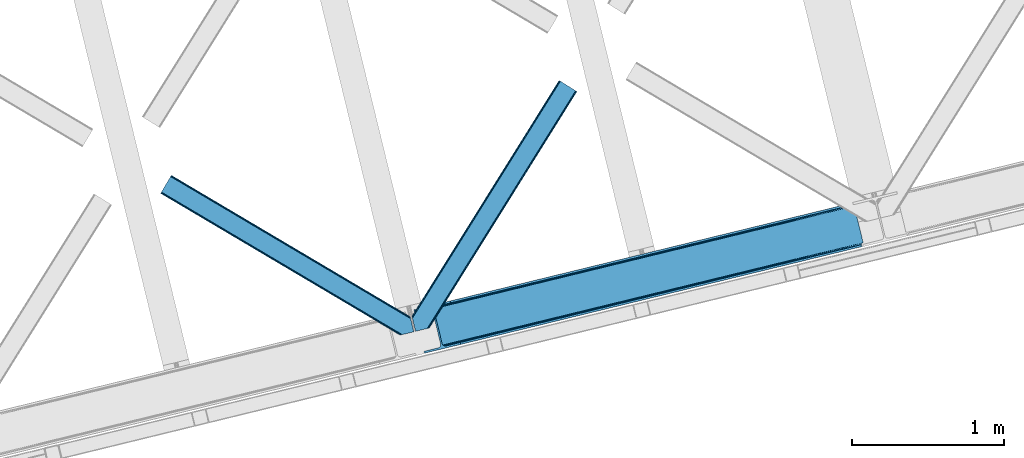
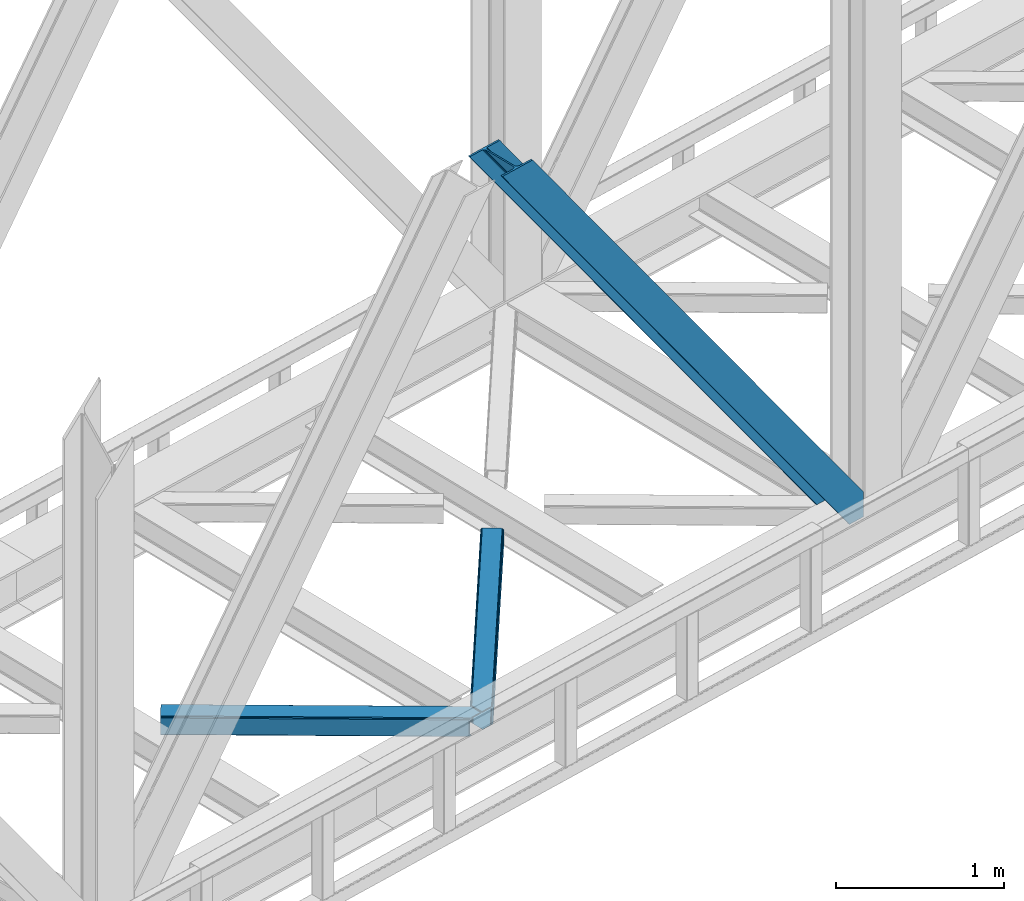
# One storey, part 64 of 93: 3 members.
"""IFC4 building model written with IfcOpenShell, lengths in millimetres."""

from ifc_helpers import new_model, entity, si_unit, converted_unit, derived_unit, direction, frame, origin, place, context, subcontext, project, spatial, triangles, type_object, element, save


model = new_model("IFC4")

# Units and contexts
model_context = context("Model", 3, precision=0.01, world=origin(), true_north=direction((6.12303176911189e-17, 1.0)))
plan_context = context("Plan", 3, precision=0.01, world=origin(), true_north=direction((6.12303176911189e-17, 1.0)))
body_context = subcontext(model_context, "Body", "Model", "MODEL_VIEW")
ifc_project = project(units=[si_unit("LENGTHUNIT", "METRE", prefix="MILLI"), si_unit("AREAUNIT", "SQUARE_METRE"), si_unit("VOLUMEUNIT", "CUBIC_METRE"), converted_unit("PLANEANGLEUNIT", "DEGREE", entity("IfcRatioMeasure", 0.0174532925199433), si_unit("PLANEANGLEUNIT", "RADIAN"), dimensions=[0, 0, 0, 0, 0, 0, 0]), si_unit("MASSUNIT", "GRAM", prefix="KILO"), derived_unit("MASSDENSITYUNIT", [(si_unit("MASSUNIT", "GRAM", prefix="KILO"), 1), (si_unit("LENGTHUNIT", "METRE"), -3)]), derived_unit("MOMENTOFINERTIAUNIT", [(si_unit("LENGTHUNIT", "METRE"), 4)]), si_unit("TIMEUNIT", "SECOND"), si_unit("FREQUENCYUNIT", "HERTZ"), si_unit("THERMODYNAMICTEMPERATUREUNIT", "DEGREE_CELSIUS"), derived_unit("THERMALTRANSMITTANCEUNIT", [(si_unit("MASSUNIT", "GRAM", prefix="KILO"), 1), (si_unit("THERMODYNAMICTEMPERATUREUNIT", "KELVIN"), -1), (si_unit("TIMEUNIT", "SECOND"), -3)]), derived_unit("VOLUMETRICFLOWRATEUNIT", [(si_unit("LENGTHUNIT", "METRE"), 3), (si_unit("TIMEUNIT", "SECOND"), -1)]), derived_unit("MASSFLOWRATEUNIT", [(si_unit("MASSUNIT", "GRAM", prefix="KILO"), 1), (si_unit("TIMEUNIT", "SECOND"), -1)]), derived_unit("ROTATIONALFREQUENCYUNIT", [(si_unit("TIMEUNIT", "SECOND"), -1)]), si_unit("ELECTRICCURRENTUNIT", "AMPERE"), si_unit("ELECTRICVOLTAGEUNIT", "VOLT"), si_unit("POWERUNIT", "WATT"), si_unit("FORCEUNIT", "NEWTON", prefix="KILO"), si_unit("ILLUMINANCEUNIT", "LUX"), si_unit("LUMINOUSFLUXUNIT", "LUMEN"), si_unit("LUMINOUSINTENSITYUNIT", "CANDELA"), derived_unit("USERDEFINED", [(si_unit("MASSUNIT", "GRAM", prefix="KILO"), -1), (si_unit("LENGTHUNIT", "METRE"), -2), (si_unit("TIMEUNIT", "SECOND"), 3), (si_unit("LUMINOUSFLUXUNIT", "LUMEN"), 1)]), derived_unit("LINEARVELOCITYUNIT", [(si_unit("LENGTHUNIT", "METRE"), 1), (si_unit("TIMEUNIT", "SECOND"), -1)]), si_unit("PRESSUREUNIT", "PASCAL"), derived_unit("USERDEFINED", [(si_unit("LENGTHUNIT", "METRE"), -2), (si_unit("MASSUNIT", "GRAM", prefix="KILO"), 1), (si_unit("TIMEUNIT", "SECOND"), -2)]), derived_unit("LINEARFORCEUNIT", [(si_unit("MASSUNIT", "GRAM", prefix="KILO"), 1), (si_unit("LENGTHUNIT", "METRE"), 1), (si_unit("TIMEUNIT", "SECOND"), -2), (si_unit("LENGTHUNIT", "METRE"), -1)]), derived_unit("PLANARFORCEUNIT", [(si_unit("MASSUNIT", "GRAM", prefix="KILO"), 1), (si_unit("LENGTHUNIT", "METRE"), 1), (si_unit("TIMEUNIT", "SECOND"), -2), (si_unit("LENGTHUNIT", "METRE"), -2)])], contexts=[model_context, plan_context])

# Site, building, storey
site_placement = place(None, origin())
site = spatial("IfcSite", under=ifc_project, at=site_placement, CompositionType="ELEMENT")
building_placement = place(site_placement, origin())
building = spatial("IfcBuilding", under=site, at=building_placement, CompositionType="ELEMENT")
storey_placement = place(building_placement, frame((0.0, 0.0, 15900.0)))
storey = spatial("IfcBuildingStorey", under=building, at=storey_placement, CompositionType="ELEMENT", Elevation=15900.0)

# Members
member_type_1 = type_object("IfcMemberType", PredefinedType="BRACE")
member_1_placement = place(storey_placement, frame((-20226.1607666016, 12536.4475799561, 3694.99929199219)))
element("IfcMember", 1, at=member_1_placement, inside=storey, type_object=member_type_1, ObjectType="Steel Vertical Brace", PredefinedType="BRACE", context=body_context, shape_type="Tessellation", body=[
    triangles([(2966.89216003418, 730.998403930664, 0.80925292968459), (2967.55374755859, 730.015905761718, 1.10690917968532), (2966.08058166504, 729.656625366211, 0.0), (2964.18534851074, 737.429406738282, 0.0), (2962.43778076172, 728.769470214844, 8.31577148437282), (2962.43778076172, 728.769470214844, 0.0), (2505.8586730957, 612.60679321289, 658.855133056641), (2511.36415100098, 609.932537841796, 662.301434326171), (2954.04410705566, 717.839904785156, 38.6743835449197), (2954.16851806641, 719.764205932617, 32.1678039550752), (2501.4112701416, 617.533236694337, 656.552947998047), (2958.54266967773, 726.957952880859, 14.8293273925774), (2955.07776489258, 722.243124389648, 26.1867736816384), (2955.64168395996, 723.796517944336, 22.4381652832017), (655.166986083983, 156.054428100586, 3289.34108276367), (649.44175415039, 156.069543457032, 3285.27854003906), (213.882293701172, 48.4865753173835, 3911.00081176758), (205.271191406249, 47.7982452392571, 3911.00081176758), (643.935113525389, 158.742636108398, 3281.83223876953), (197.320513916016, 49.8760253906257, 3911.00081176758), (639.488873291015, 163.67024230957, 3279.53005371094), (191.241815185545, 54.4048187255867, 3911.00081176758), (636.782061767579, 170.100082397461, 3278.7231262207), (187.962945556639, 60.6951324462898, 3911.00081176758), (2954.16037902832, 716.45859375, 50.6410949707024), (2517.08822021484, 609.917422485352, 666.36397705078), (2051.60733032227, 496.451092529296, 1322.10767211914), (2045.8832611084, 496.466207885742, 1318.04512939453), (1580.40353393555, 383.001040649415, 1973.78882446289), (1586.12760314941, 382.985925292969, 1977.85369262695), (1114.92264404297, 269.534710693359, 2629.53251953125), (1120.64671325684, 269.519595336915, 2633.59738769531), (2040.37778320312, 499.140463256836, 1314.598828125), (1574.89689331055, 385.675296020509, 1970.34484863281), (1109.41600341797, 272.208966064452, 2626.08854370117), (2035.93154296875, 504.066906738281, 1312.29896850586), (1570.45065307617, 390.601739501953, 1968.04266357422), (1104.96976318359, 277.135409545899, 2623.78635864258), (2498.70445861816, 623.963076782227, 655.74602050781), (2033.22473144531, 510.497909545898, 1311.48971557617), (1567.74384155273, 397.031579589844, 1967.23341064453), (1102.26295166016, 283.566412353515, 2622.97710571289), (2909.00499572754, 963.80047302246, 0.0), (2443.52410583496, 850.335305786133, 655.74602050781), (1978.04437866211, 736.868975830079, 1311.48971557617), (1512.56348876953, 623.40380859375, 1967.23341064453), (1047.08259887695, 509.937478637696, 2622.97710571289), (581.601708984374, 396.471148681641, 3278.7231262207), (132.782592773438, 287.067361450196, 3911.00081176758), (307.434722900391, 71.2909973144524, 3911.00081176758), (2954.16037902832, 716.45859375, 182.433050537107), (2954.3522277832, 715.476095581054, 0.0), (2954.16851806641, 719.764205932617, 0.0), (2954.3522277832, 715.476095581054, 182.495837402341), (2955.64168395996, 723.796517944336, 0.0), (2958.54266967773, 726.957952880859, 0.0), (2957.19391479492, 703.817504882813, 182.495837402341), (310.513604736327, 58.6603729248054, 3911.00081176758), (2957.19391479492, 703.817504882813, 0.0), (2846.09139404297, 676.734274291992, 0.0), (69.8631774902351, 0.0, 3911.00081176758), (2843.01251220703, 689.364898681641, 0.0), (66.7842956542954, 12.6294616699215, 3911.00081176758), (160.336724853514, 35.4338836669922, 3911.00081176758), (2936.56494140625, 712.169320678711, 0.0), (2953.96039123535, 734.936535644531, 0.0), (2953.94178771973, 727.841619873047, 0.0), (177.731011962889, 58.2010986328132, 3911.00081176758), (177.719384765624, 51.108508300782, 3911.00081176758), (2950.63036193847, 721.02459411621, 0.0), (174.403308105469, 44.2891571044929, 3911.00081176758), (2944.52840881348, 715.520278930664, 0.0), (168.299029541016, 38.7860046386722, 3911.00081176758), (2898.78003845215, 961.308764648438, 0.0), (122.550659179688, 284.573327636719, 3911.00081176758), (2872.85952758789, 973.517321777344, 0.0), (2881.47062988281, 974.205651855469, 0.0), (105.242413330077, 297.47021484375, 3911.00081176758), (96.6313110351548, 296.781884765625, 3911.00081176758), (2889.42130737305, 972.127871704102, 0.0), (113.19309082031, 295.392434692383, 3911.00081176758), (2895.49884338379, 967.599078369141, 0.0), (119.276440429687, 290.864804077148, 3911.00081176758), (3.07888183593604, 273.977462768555, 3911.00081176758), (2779.30709838867, 950.712899780274, 0.0), (2776.22821655273, 963.342361450195, 0.0), (0.0, 286.608087158203, 3911.00081176758), (142.21457519531, 306.482455444337, 3911.00081176758), (150.176879882813, 309.834576416015, 3911.00081176758), (136.110296630857, 300.979302978516, 3911.00081176758), (132.798870849609, 294.161114501952, 3911.00081176758), (240.650427246092, 345.268460083007, 3911.00081176758), (243.729309082031, 332.638998413086, 3911.00081176758), (2887.33073730469, 990.425592041016, 182.495837402341), (2887.33073730469, 990.425592041016, 0.0), (2890.45496520996, 977.805432128906, 182.433050537107), (2890.17242431641, 978.767001342774, 182.495837402341), (1522.42102661133, 644.332763671875, 1977.85369262695), (591.459246826173, 417.401266479492, 3289.34108276367), (1056.94013671875, 530.867596435546, 2633.59738769531), (1987.90191650391, 757.799093627929, 1322.10767211914), (2453.38164367676, 871.265423583984, 666.36397705078), (2890.45496520996, 977.805432128906, 50.6410949707024), (2890.17242431641, 978.767001342774, 0.0), (2890.986328125, 976.525277709961, 38.6743835449197), (2892.14904785156, 974.998626708984, 33.1630920410134), (2891.98277893066, 974.875378417968, 0.0), (2893.5687286377, 973.138275146484, 26.4425720214822), (2895.14653930664, 971.973229980469, 22.4381652832017), (2903.46812438965, 970.684936523438, 8.31577148437282), (2903.46812438965, 970.684936523438, 0.0), (2899.17652587891, 970.50122680664, 0.0), (2899.17652587891, 970.50122680664, 14.8293273925774), (2895.14653930664, 971.973229980469, 0.0), (2907.11092529297, 971.573254394531, 0.0), (2444.64961853027, 863.710070800782, 658.855133056641), (2442.96832580566, 857.289532470702, 656.552947998047), (2908.44921569824, 970.755862426759, 0.80925292968459), (2908.58409118652, 971.932534790039, 1.10690917968532), (581.045928955078, 403.426538085938, 3279.53005371094), (582.727221679688, 409.845913696288, 3281.83223876953), (586.385137939451, 414.753753662109, 3285.27854003906), (2448.30753479004, 868.617910766601, 662.301434326171), (1977.48859863281, 743.823202514648, 1312.29896850586), (1512.00770874024, 630.358035278321, 1968.04266357422), (1046.52681884765, 516.891705322265, 2623.78635864258), (1979.16872863769, 750.243740844726, 1314.598828125), (1513.68783874512, 636.778573608399, 1970.34484863281), (1048.20694885254, 523.312243652344, 2626.08854370117), (1982.82664489746, 755.151580810547, 1318.04512939453), (1517.34575500488, 641.686413574218, 1973.78882446289), (1051.8648651123, 528.220083618164, 2629.53251953125)], [[1, 2, 3], [3, 4, 1], [2, 5, 6], [6, 3, 2], [7, 8, 9], [9, 10, 7], [11, 12, 5], [5, 1, 11], [11, 7, 13], [13, 14, 11], [14, 12, 11], [15, 16, 17], [18, 17, 16], [16, 19, 18], [20, 18, 19], [19, 21, 20], [22, 20, 21], [21, 23, 22], [24, 22, 23], [5, 2, 1], [10, 13, 7], [25, 9, 8], [8, 26, 25], [26, 8, 27], [28, 27, 8], [27, 28, 29], [29, 30, 27], [30, 29, 31], [31, 32, 30], [32, 31, 16], [16, 15, 32], [8, 7, 33], [33, 28, 8], [28, 33, 29], [34, 29, 33], [29, 34, 31], [35, 31, 34], [31, 35, 16], [19, 16, 35], [7, 11, 33], [36, 33, 11], [33, 36, 34], [37, 34, 36], [34, 37, 35], [38, 35, 37], [35, 38, 21], [21, 19, 35], [1, 4, 39], [39, 11, 1], [11, 39, 40], [40, 36, 11], [36, 40, 41], [41, 37, 36], [37, 41, 42], [42, 38, 37], [38, 42, 23], [23, 21, 38], [4, 43, 44], [45, 39, 44], [41, 40, 45], [41, 45, 46], [44, 39, 4], [45, 40, 39], [42, 41, 46], [46, 47, 42], [47, 48, 23], [49, 24, 48], [47, 23, 42], [48, 24, 23], [50, 51, 30], [30, 32, 50], [32, 15, 50], [17, 50, 15], [27, 30, 51], [51, 25, 26], [26, 27, 51], [52, 9, 25], [52, 53, 10], [10, 9, 52], [25, 51, 54], [54, 52, 25], [14, 53, 55], [53, 14, 13], [10, 53, 13], [56, 12, 55], [14, 55, 12], [6, 5, 56], [12, 56, 5], [57, 54, 58], [54, 51, 50], [50, 58, 54], [57, 59, 52], [52, 54, 57], [58, 60, 57], [58, 61, 60], [60, 59, 57], [62, 60, 61], [61, 63, 62], [63, 64, 62], [65, 62, 64], [66, 67, 68], [69, 68, 67], [67, 70, 69], [71, 69, 70], [70, 72, 71], [73, 71, 72], [72, 65, 73], [64, 73, 65], [74, 66, 68], [68, 75, 74], [76, 77, 78], [78, 79, 76], [77, 80, 81], [81, 78, 77], [80, 82, 83], [83, 81, 80], [82, 74, 75], [75, 83, 82], [79, 84, 85], [85, 76, 79], [86, 85, 87], [84, 87, 85], [75, 68, 49], [71, 73, 18], [64, 61, 17], [63, 61, 64], [73, 64, 17], [68, 69, 22], [69, 71, 20], [81, 88, 78], [87, 79, 89], [79, 78, 89], [87, 84, 79], [81, 83, 90], [83, 75, 91], [49, 68, 24], [17, 18, 73], [22, 69, 20], [18, 20, 71], [22, 24, 68], [58, 17, 61], [58, 50, 17], [89, 78, 88], [90, 83, 91], [49, 91, 75], [90, 88, 81], [89, 92, 87], [92, 89, 93], [92, 86, 87], [86, 92, 94], [95, 86, 94], [96, 97, 93], [97, 94, 92], [92, 93, 97], [98, 96, 93], [93, 99, 100], [99, 93, 89], [100, 98, 93], [96, 98, 101], [101, 102, 96], [103, 96, 102], [97, 104, 94], [95, 94, 104], [104, 105, 106], [96, 103, 97], [104, 97, 103], [103, 105, 104], [107, 108, 109], [107, 106, 108], [110, 111, 112], [112, 113, 110], [113, 112, 114], [114, 109, 113], [109, 114, 107], [106, 107, 104], [53, 70, 55], [76, 86, 95], [85, 86, 76], [77, 76, 95], [104, 80, 77], [77, 95, 104], [104, 107, 80], [60, 65, 59], [52, 72, 70], [65, 72, 59], [60, 62, 65], [70, 53, 52], [52, 59, 72], [43, 66, 74], [82, 112, 74], [80, 114, 82], [80, 107, 114], [82, 114, 112], [111, 43, 74], [112, 111, 74], [43, 111, 115], [4, 66, 43], [56, 66, 6], [55, 70, 67], [67, 66, 56], [56, 55, 67], [4, 6, 66], [3, 6, 4], [116, 113, 109], [117, 118, 113], [113, 116, 117], [109, 108, 116], [118, 119, 110], [110, 113, 118], [48, 120, 91], [91, 49, 48], [120, 121, 90], [90, 91, 120], [121, 122, 88], [88, 90, 121], [122, 99, 89], [89, 88, 122], [105, 103, 123], [102, 123, 103], [106, 116, 108], [116, 106, 105], [123, 116, 105], [43, 118, 44], [117, 44, 118], [44, 117, 45], [124, 45, 117], [45, 124, 46], [125, 46, 124], [46, 125, 47], [126, 47, 125], [47, 126, 48], [120, 48, 126], [117, 116, 127], [127, 124, 117], [124, 127, 128], [128, 125, 124], [125, 128, 129], [129, 126, 125], [126, 129, 121], [121, 120, 126], [116, 123, 127], [130, 127, 123], [127, 130, 131], [131, 128, 127], [128, 131, 132], [132, 129, 128], [129, 132, 122], [122, 121, 129], [123, 102, 101], [101, 130, 123], [130, 101, 131], [98, 131, 101], [131, 98, 132], [100, 132, 98], [132, 100, 122], [99, 122, 100], [110, 119, 111], [115, 111, 119], [119, 118, 115], [43, 115, 118]]),
])
member_type_2 = type_object("IfcMemberType", PredefinedType="BRACE")
member_2_placement = place(storey_placement, frame((-20238.8832458496, 12681.0701477051, 3510.00011901855)))
element("IfcMember", 2, at=member_2_placement, inside=storey, type_object=member_type_2, ObjectType="Steel Horizontal Brace", PredefinedType="BRACE", context=body_context, shape_type="Tessellation", body=[
    triangles([(986.150271606446, 1647.42851257324, 0.0), (1075.22041625977, 1591.8260925293, 0.0), (119.788037109374, 259.603921508789, 0.0), (154.548706054688, 117.003323364257, 0.0), (115.902227783205, 275.544808959961, 4.52065429687718), (117.571893310549, 268.698715209961, 1.33247680664135), (158.434515380861, 101.062435913085, 4.52065429687718), (156.767175292971, 107.908529663086, 1.33247680664135), (114.825549316407, 275.742471313477, 5.52059326172093), (115.130181884768, 275.922692871094, 5.35316162109666), (158.132208251955, 99.1218566894531, 5.27525939941552), (115.439465332031, 276.107565307617, 5.18107910156323), (158.236853027345, 99.7776306152336, 5.02062377929906), (158.188018798828, 99.4811370849602, 5.13573303222802), (115.54178466797, 276.166864013672, 5.12526855468968), (115.685961914063, 275.921530151367, 4.88574829101708), (158.339172363281, 100.434567260741, 4.76482543945531), (158.032214355469, 98.4928253173821, 5.52059326172093), (1085.71628723145, 1585.27300415039, 5.12526855468968), (1080.90495300293, 1588.28096008301, 1.33247680664135), (1088.93469543457, 1583.26498718262, 10.8028289794929), (114.209307861329, 21.8521545410149, 10.8028289794929), (109.470062255859, 20.6964111328125, 5.52059326172093), (1090.0695098877, 1582.56037902832, 17.5000946044929), (116.062683105469, 22.3044525146488, 17.5000946044929), (6.7507507324226, 102.618154907226, 5.52059326172093), (31.3608764648452, 1.65687561035156, 5.52059326172093), (1090.0695098877, 1582.56037902832, 122.500662231447), (116.062683105469, 22.3044525146488, 122.500662231447), (1088.93469543457, 1583.26498718262, 129.197927856447), (114.209307861329, 21.8521545410149, 129.197927856447), (1085.71628723145, 1585.27300415039, 134.874325561526), (108.935211181641, 20.5673492431633, 134.874325561526), (1080.90495300293, 1588.28096008301, 138.667117309571), (101.042669677736, 18.6430480957024, 138.667117309571), (1075.22041625977, 1591.8260925293, 139.999594116212), (91.7292846679702, 16.3722564697255, 139.999594116212), (980.470385742188, 1650.97480773926, 1.33247680664135), (975.654400634765, 1653.98160095215, 5.12526855468968), (1.68826904297021, 100.410150146485, 10.9621215820334), (972.435992431641, 1655.99078063965, 10.8028289794929), (971.306991577148, 1656.69655151367, 17.5000946044929), (0.239520263672603, 99.7776306152336, 12.5201660156272), (0.0, 100.760128784179, 17.5000946044929), (5.79266967773583, 76.992974853516, 139.999594116212), (986.150271606446, 1647.42851257324, 139.999594116212), (24.5612915039055, 0.0, 139.999594116212), (971.306991577148, 1656.69655151367, 122.500662231447), (0.0, 100.760128784179, 122.500662231447), (980.470385742188, 1650.97480773926, 138.667117309571), (3.57652587890698, 86.088931274413, 138.667117309571), (975.654400634765, 1653.98160095215, 134.874325561526), (1.69524536133031, 93.7989257812496, 134.874325561526), (972.435992431641, 1655.99078063965, 129.197927856447), (0.439508056642808, 98.9509368896488, 129.197927856447), (29.9237548828132, 1.30689697265552, 6.99957275390625), (12.1969299316406, 74.0326904296871, 6.99957275390625), (8.99479980468823, 81.5485107421864, 8.3320495605476), (3.88813476562427, 84.8111022949215, 12.5201660156272), (1069.28589477539, 1595.53400573731, 6.99957275390625), (81.9973205566421, 14.000308227538, 6.99957275390625), (992.090606689453, 1643.72176208496, 6.99957275390625), (981.593572998048, 1650.27485046387, 12.1260040283232), (978.375164794921, 1652.28403015137, 17.8035644531265), (2.75797119140771, 89.4445404052731, 17.8035644531265), (986.409558105468, 1647.2692199707, 8.3320495605476), (977.246163940432, 1652.98980102539, 24.4996673583992), (2.31613769531396, 91.2537322998051, 24.4996673583992), (977.246163940432, 1652.98980102539, 115.501089477541), (2.31613769531396, 91.2537322998051, 115.501089477541), (4.01370849609521, 84.2925292968739, 127.87475280762), (2.75797119140771, 89.4445404052731, 122.196029663086), (5.89266357422093, 76.5813720703118, 131.667544555665), (8.11113281250073, 67.4865783691403, 133.000021362306), (24.5612915039055, 0.0, 133.000021362306), (978.375164794921, 1652.28403015137, 122.196029663086), (981.593572998048, 1650.27485046387, 127.87475280762), (986.409558105468, 1647.2692199707, 131.667544555665), (992.090606689453, 1643.72176208496, 133.000021362306), (1069.28589477539, 1595.53400573731, 133.000021362306), (81.9973205566421, 14.000308227538, 133.000021362306), (1079.78176574707, 1588.9809173584, 12.1260040283232), (1083.0001739502, 1586.9717376709, 17.8035644531265), (1084.12917480469, 1586.2671295166, 24.4996673583992), (1074.96578063965, 1591.98771057129, 8.3320495605476), (1079.78176574707, 1588.9809173584, 127.87475280762), (1084.12917480469, 1586.2671295166, 115.501089477541), (1083.0001739502, 1586.9717376709, 122.196029663086), (1074.96578063965, 1591.98771057129, 131.667544555665), (91.3083801269531, 16.2699371337894, 131.667544555665), (99.2032470703125, 18.1942382812504, 127.87475280762), (104.477343750001, 19.4802062988274, 122.196029663086), (106.32839355469, 19.931341552734, 115.501089477541), (91.3083801269531, 16.2699371337894, 8.3320495605476), (104.477343750001, 19.4802062988274, 17.8035644531265), (99.2032470703125, 18.1942382812504, 12.1260040283232), (106.32839355469, 19.931341552734, 24.4996673583992)], [[1, 2, 3], [4, 3, 2], [5, 3, 4], [3, 5, 6], [4, 7, 5], [7, 4, 8], [9, 10, 11], [10, 12, 13], [13, 14, 10], [12, 15, 16], [16, 17, 12], [16, 5, 7], [7, 17, 16], [17, 13, 12], [14, 11, 10], [11, 18, 9], [19, 14, 13], [13, 20, 19], [13, 17, 20], [17, 7, 20], [7, 8, 20], [21, 22, 18], [18, 19, 21], [14, 19, 11], [18, 11, 19], [22, 23, 18], [21, 24, 25], [25, 22, 21], [2, 20, 4], [8, 4, 20], [23, 26, 18], [23, 27, 26], [9, 18, 26], [24, 28, 29], [29, 25, 24], [28, 30, 29], [31, 29, 30], [30, 32, 31], [33, 31, 32], [32, 34, 33], [35, 33, 34], [34, 36, 35], [37, 35, 36], [38, 6, 5], [5, 39, 38], [5, 15, 39], [40, 41, 9], [41, 39, 15], [42, 41, 40], [40, 43, 42], [43, 44, 42], [9, 26, 40], [38, 1, 6], [3, 6, 1], [36, 45, 37], [36, 46, 45], [45, 47, 37], [48, 42, 44], [44, 49, 48], [46, 50, 51], [51, 45, 46], [50, 52, 53], [53, 51, 50], [52, 54, 55], [55, 53, 52], [54, 48, 49], [49, 55, 54], [27, 56, 57], [26, 57, 58], [57, 26, 27], [59, 40, 26], [26, 58, 59], [43, 40, 59], [60, 57, 61], [60, 62, 57], [57, 56, 61], [63, 64, 65], [65, 59, 63], [66, 63, 59], [62, 66, 58], [58, 57, 62], [59, 58, 66], [64, 67, 68], [68, 65, 64], [67, 69, 68], [70, 68, 69], [71, 53, 72], [73, 74, 45], [74, 47, 45], [74, 75, 47], [51, 73, 45], [71, 51, 53], [71, 73, 51], [49, 68, 70], [55, 72, 53], [70, 72, 49], [72, 55, 49], [44, 68, 49], [43, 59, 65], [65, 68, 44], [44, 43, 65], [69, 76, 70], [72, 70, 76], [76, 77, 72], [71, 72, 77], [77, 78, 71], [73, 71, 78], [78, 79, 73], [74, 73, 79], [80, 74, 79], [74, 80, 81], [75, 74, 81], [21, 82, 83], [84, 28, 24], [21, 83, 24], [21, 19, 82], [83, 84, 24], [82, 19, 20], [60, 2, 1], [2, 85, 20], [85, 2, 60], [85, 82, 20], [30, 86, 32], [87, 28, 84], [28, 88, 30], [88, 28, 87], [30, 88, 86], [36, 80, 46], [34, 32, 86], [86, 89, 34], [89, 80, 36], [36, 34, 89], [63, 38, 39], [1, 62, 60], [1, 66, 62], [66, 1, 38], [63, 66, 38], [67, 42, 48], [41, 64, 63], [39, 41, 63], [64, 41, 42], [67, 64, 42], [50, 77, 52], [46, 80, 79], [79, 78, 46], [78, 77, 50], [50, 46, 78], [54, 52, 77], [48, 69, 67], [76, 48, 54], [48, 76, 69], [76, 54, 77], [35, 37, 90], [47, 81, 37], [81, 47, 75], [81, 90, 37], [91, 35, 90], [91, 33, 35], [33, 92, 31], [92, 33, 91], [29, 92, 93], [92, 29, 31], [61, 23, 94], [95, 96, 23], [96, 94, 23], [61, 27, 23], [27, 61, 56], [97, 95, 25], [22, 25, 95], [29, 97, 25], [97, 29, 93], [95, 23, 22], [80, 89, 90], [90, 81, 80], [89, 86, 91], [91, 90, 89], [86, 88, 92], [92, 91, 86], [88, 87, 93], [93, 92, 88], [87, 84, 97], [97, 93, 87], [84, 83, 97], [95, 97, 83], [83, 82, 95], [96, 95, 82], [82, 85, 96], [94, 96, 85], [85, 60, 94], [61, 94, 60]]),
])
member_type_3 = type_object("IfcMemberType", PredefinedType="BRACE")
member_3_placement = place(storey_placement, frame((-21897.5192138672, 12655.9240081787, 3510.00011901855)))
element("IfcMember", 3, at=member_3_placement, inside=storey, type_object=member_type_3, ObjectType="Steel Horizontal Brace", PredefinedType="BRACE", context=body_context, shape_type="Tessellation", body=[
    triangles([(1467.52902832031, 208.965151977538, 0.0), (1502.28969726562, 66.3657165527329, 0.0), (8.91573486327979, 950.478030395507, 0.0), (62.405493164064, 1040.83065490723, 0.0), (0.679028320311772, 936.564926147461, 10.8028289794929), (1582.26156005859, 0.541827392577034, 10.8679412841811), (1580.03843994141, 0.0, 17.5000946044929), (1508.64744873047, 44.5007720947251, 9.52034912109593), (2.6114685058601, 939.829843139647, 5.12526855468968), (1506.38479614258, 49.5597656249993, 5.12526855468968), (1507.26148681641, 45.9657989501939, 8.52041015625218), (1508.31258544922, 44.8554016113267, 9.27850341796875), (1507.95214233398, 45.2332855224595, 9.02037963867406), (1507.59635009766, 45.6123321533196, 8.76225585937573), (1582.7126953125, 0.651123046875, 9.52034912109593), (1504.50584106445, 57.2697601318359, 1.33247680664135), (5.50431518554615, 944.715591430664, 1.33247680664135), (0.0, 935.41848449707, 17.5000946044929), (1580.03843994141, 0.0, 122.500662231447), (0.0, 935.41848449707, 122.500662231447), (1595.05845336914, 3.66024169921729, 138.667117309571), (1604.36951293945, 5.93103332519422, 139.999594116212), (8.91573486327979, 950.478030395507, 139.999594116212), (5.50431518554615, 944.715591430664, 138.667117309571), (1587.16358642578, 1.73710327148365, 134.874325561526), (2.6114685058601, 939.829843139647, 134.874325561526), (1581.88948974609, 0.451135253904795, 129.197927856447), (0.679028320311772, 936.564926147461, 129.197927856447), (1502.33388061524, 66.183169555663, 8.52041015625218), (1502.68967285156, 65.0390533447262, 8.90294494629052), (1503.18034057617, 64.3204925537102, 9.10758361816625), (1503.67798461914, 63.5914672851559, 9.31571044922021), (1504.1709777832, 62.8729064941399, 9.52034912109593), (1601.52317504883, 5.23688964843677, 9.52034912109593), (9.07153930664208, 950.739642333983, 8.3320495605476), (1502.18272705078, 66.8063873291012, 8.42274169922166), (6.1786926269524, 945.853894042968, 12.1260040283232), (1596.89555053711, 4.10905151367115, 12.1260040283232), (1499.97123413086, 75.8721130371086, 6.99957275390625), (12.4829589843757, 956.502081298828, 6.99957275390625), (1591.62377929688, 2.82424621581958, 17.8035644531265), (4.24625244140771, 942.58897705078, 17.8035644531265), (1589.77040405274, 2.3719482421875, 24.4996673583992), (3.56722412109229, 941.442535400391, 24.4996673583992), (1469.84749145508, 199.458755493164, 6.99957275390625), (58.8429199218735, 1034.80776672363, 6.99957275390625), (1462.55723876953, 229.365069580077, 8.52041015625218), (1467.4848449707, 209.147698974608, 8.52041015625218), (1463.4316040039, 225.771102905273, 5.12526855468968), (1467.63599853516, 208.524481201172, 8.42274169922166), (1465.31288452149, 218.061108398437, 1.33247680664135), (1589.77040405274, 2.3719482421875, 115.501089477541), (3.56722412109229, 941.442535400391, 115.501089477541), (1591.62377929688, 2.82424621581958, 122.196029663086), (4.24625244140771, 942.58897705078, 122.196029663086), (1596.89555053711, 4.10905151367115, 127.87475280762), (6.1786926269524, 945.853894042968, 127.87475280762), (1604.79041748047, 6.03335266113208, 131.667544555665), (9.07153930664208, 950.739642333983, 131.667544555665), (1614.10380249023, 8.30298156738172, 133.000021362306), (12.4829589843757, 956.502081298828, 133.000021362306), (1671.53983154297, 22.304452514647, 139.999594116212), (1671.53983154297, 22.304452514647, 133.000021362306), (1652.7712097168, 99.297427368163, 139.999594116212), (62.405493164064, 1040.83065490723, 139.999594116212), (1655.08734741211, 89.7910308837891, 133.000021362306), (58.8429199218735, 1034.80776672363, 133.000021362306), (1647.4180480957, 121.255389404296, 129.197927856447), (1646.97854003906, 123.064581298828, 122.500662231447), (70.642199707032, 1054.74375915527, 129.197927856447), (71.3258789062493, 1055.89020080566, 122.500662231447), (1648.67378540039, 116.103378295898, 134.874325561526), (68.7144104003892, 1051.48000488281, 134.874325561526), (1650.55274047852, 108.393383789062, 138.667117309571), (65.8215637207031, 1046.5942565918, 138.667117309571), (1646.97854003906, 123.064581298828, 17.5000946044929), (71.3258789062493, 1055.89020080566, 17.5000946044929), (70.642199707032, 1054.74375915527, 10.8028289794929), (65.1471862792969, 1045.45595397949, 12.1260040283232), (67.0796264648452, 1048.72087097168, 17.8035644531265), (67.7563293457024, 1049.86731262207, 24.4996673583992), (68.7144104003892, 1051.48000488281, 5.12526855468968), (65.8215637207031, 1046.5942565918, 1.33247680664135), (62.2543395996108, 1040.57020568848, 8.3320495605476), (65.1471862792969, 1045.45595397949, 127.87475280762), (67.7563293457024, 1049.86731262207, 115.501089477541), (67.0796264648452, 1048.72087097168, 122.196029663086), (62.2543395996108, 1040.57020568848, 131.667544555665), (1649.29467773438, 113.558184814452, 24.4996673583992), (1649.29467773438, 113.558184814452, 115.501089477541), (1652.87120361328, 98.8858245849606, 131.667544555665), (1650.99224853516, 106.596981811523, 127.87475280762), (1649.73651123047, 111.748992919922, 122.196029663086), (1649.82487792969, 111.385061645507, 17.8686767578147), (1649.93184814453, 110.943228149414, 16.5199218750022), (1646.98551635742, 123.027374267578, 16.5199218750022), (1640.69752807617, 124.970278930663, 10.8702667236357), (1462.77583007812, 229.699932861327, 9.22734375000073), (1462.66420898437, 229.532501220703, 8.87387695312646), (1463.57578125, 229.405764770507, 9.52034912109593), (1639.19529418945, 125.435366821288, 9.52034912109593), (1645.70419921875, 109.725860595703, 12.1260040283232), (1468.05457763672, 211.033630371094, 9.52034912109593), (1643.67409057617, 107.063232421875, 9.52034912109593)], [[1, 2, 3], [3, 4, 1], [5, 6, 7], [6, 5, 8], [5, 9, 10], [10, 11, 5], [12, 5, 13], [12, 8, 5], [5, 14, 13], [5, 11, 14], [8, 15, 6], [16, 10, 9], [9, 17, 16], [2, 16, 17], [17, 3, 2], [7, 18, 5], [7, 19, 18], [20, 18, 19], [21, 22, 23], [23, 24, 21], [25, 21, 24], [24, 26, 25], [27, 25, 26], [26, 28, 27], [19, 27, 28], [28, 20, 19], [11, 29, 30], [14, 30, 31], [13, 31, 32], [12, 32, 33], [33, 8, 12], [32, 12, 13], [31, 13, 14], [30, 14, 11], [34, 15, 33], [8, 33, 15], [35, 30, 29], [32, 35, 33], [35, 32, 31], [30, 35, 31], [29, 36, 35], [37, 38, 33], [33, 35, 37], [38, 34, 33], [35, 36, 39], [39, 40, 35], [41, 38, 37], [37, 42, 41], [43, 41, 42], [42, 44, 43], [39, 45, 40], [46, 40, 45], [1, 45, 39], [47, 48, 49], [48, 50, 1], [45, 1, 50], [48, 51, 49], [48, 1, 51], [2, 1, 39], [2, 39, 36], [29, 2, 36], [11, 10, 29], [29, 16, 2], [29, 10, 16], [52, 43, 44], [44, 53, 52], [54, 52, 55], [53, 55, 52], [56, 54, 57], [55, 57, 54], [58, 56, 59], [57, 59, 56], [60, 58, 61], [59, 61, 58], [56, 58, 21], [25, 56, 21], [25, 27, 54], [56, 25, 54], [54, 27, 19], [58, 22, 21], [62, 60, 63], [62, 22, 60], [58, 60, 22], [54, 19, 52], [43, 7, 41], [19, 43, 52], [7, 6, 41], [19, 7, 43], [15, 41, 6], [38, 41, 15], [34, 38, 15], [22, 64, 23], [22, 62, 64], [65, 23, 64], [66, 60, 61], [60, 66, 63], [61, 67, 66], [68, 69, 70], [71, 70, 69], [72, 68, 73], [70, 73, 68], [74, 72, 75], [73, 75, 72], [64, 74, 65], [75, 65, 74], [69, 76, 71], [77, 71, 76], [78, 79, 80], [81, 71, 77], [78, 80, 77], [78, 82, 79], [80, 81, 77], [79, 82, 83], [46, 4, 3], [4, 84, 83], [84, 4, 46], [84, 79, 83], [70, 85, 73], [86, 71, 81], [71, 87, 70], [87, 71, 86], [70, 87, 85], [65, 67, 23], [75, 73, 85], [85, 88, 75], [88, 67, 65], [65, 75, 88], [37, 17, 9], [3, 40, 46], [3, 35, 40], [35, 3, 17], [37, 35, 17], [44, 18, 20], [5, 42, 37], [9, 5, 37], [42, 5, 18], [44, 42, 18], [24, 57, 26], [23, 67, 61], [61, 59, 23], [59, 57, 24], [24, 23, 59], [28, 26, 57], [20, 53, 44], [55, 20, 28], [20, 55, 53], [55, 28, 57], [89, 90, 81], [86, 81, 90], [91, 66, 67], [67, 88, 91], [92, 91, 88], [88, 85, 92], [93, 92, 85], [85, 87, 93], [90, 93, 87], [87, 86, 90], [92, 72, 74], [66, 91, 64], [91, 92, 74], [94, 95, 96], [63, 66, 62], [64, 62, 66], [91, 74, 64], [94, 76, 89], [69, 90, 89], [89, 76, 69], [94, 96, 76], [69, 93, 90], [93, 72, 92], [72, 93, 68], [69, 68, 93], [77, 76, 97], [76, 96, 97], [98, 99, 82], [47, 82, 99], [47, 49, 82], [78, 97, 100], [100, 82, 78], [100, 98, 82], [97, 101, 100], [51, 1, 4], [4, 83, 51], [49, 51, 83], [83, 82, 49], [97, 78, 77], [80, 79, 102], [102, 95, 80], [80, 94, 89], [46, 45, 50], [103, 102, 79], [103, 104, 102], [50, 79, 84], [50, 103, 79], [50, 84, 46], [89, 81, 80], [95, 94, 80], [96, 102, 97], [102, 96, 95], [102, 101, 97], [102, 104, 101], [101, 104, 103], [103, 100, 101]]),
])

save(model, "model.ifc")
